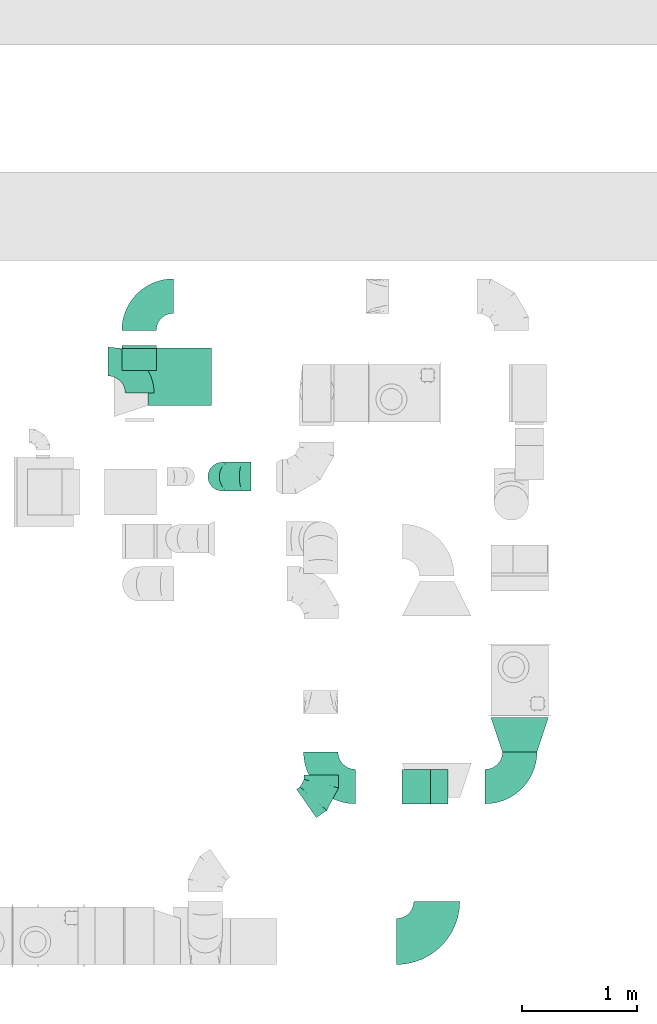
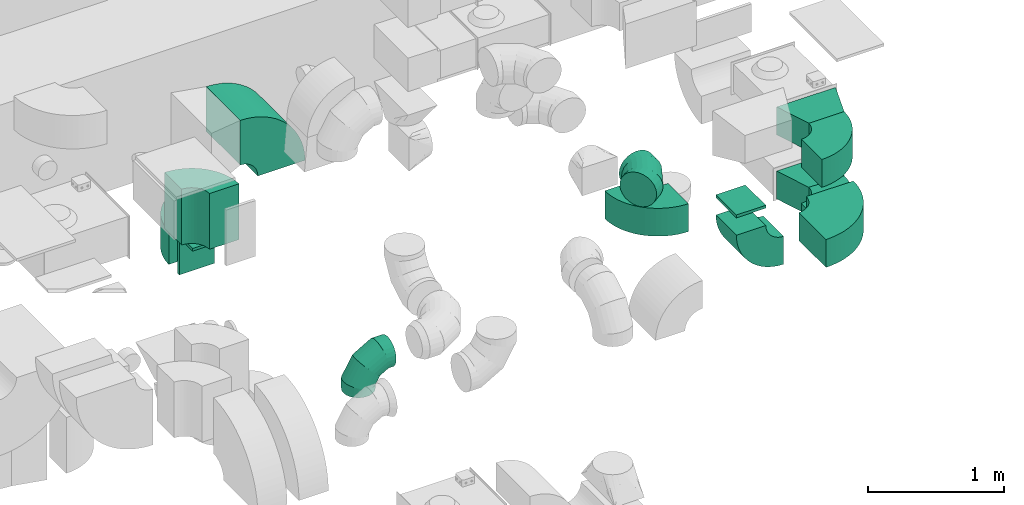
# One storey, part 11 of 59: 15 flow fittings.
"""IFC2X3 building model written with IfcOpenShell, lengths in millimetres."""

import ifcopenshell
import ifcopenshell.guid

model = None  # the IFC model being written
_history = None  # IfcOwnerHistory: only IFC2X3 demands one
_inside = {}  # id of a spatial element -> (the spatial element, [elements in it])
_under = {}  # id of a project, library or spatial element -> (it, [spatial elements below it])
_declared = {}  # id of a project -> (the project, [libraries it declares])
_typed = {}  # id of a type object -> (the type object, [elements of that type])
_made_of = {}  # id of a material, layer set ... -> (it, [elements and type objects made of it])


def new_model(schema):
    """Start an empty IFC model of exactly this schema.

    Asked for "IFC4X3", IfcOpenShell would pick the latest addendum, in which some entities
    have other attributes; the version numbers below select the first issue.
    IFC2X3 requires an IfcOwnerHistory on every rooted entity: one is made here for all.
    """
    global model, _history
    if schema == "IFC4X3":
        model = ifcopenshell.file(schema_version=(4, 3, 0, 0))
    else:
        model = ifcopenshell.file(schema=schema)
    _inside.clear()
    _under.clear()
    _declared.clear()
    _typed.clear()
    _made_of.clear()
    _history = None
    if model.schema == "IFC2X3":
        org = make("IfcOrganization", Name="unknown")
        user = make(
            "IfcPersonAndOrganization",
            ThePerson=make("IfcPerson", FamilyName="unknown"),
            TheOrganization=org,
        )
        app = make(
            "IfcApplication",
            ApplicationDeveloper=org,
            Version="unknown",
            ApplicationFullName="unknown",
            ApplicationIdentifier="unknown",
        )
        _history = make(
            "IfcOwnerHistory",
            OwningUser=user,
            OwningApplication=app,
            ChangeAction="ADDED",
            CreationDate=0,
        )
    return model


def make(cls, **values):
    """One entity of the class cls with the attributes given. An attribute that is None is left unset."""
    return model.create_entity(
        cls, **{name: value for name, value in values.items() if value is not None}
    )


def entity(cls, *values):
    """Any entity or typed value of the class cls, its attributes in the order of the schema. None: left unset."""
    e = model.create_entity(cls)
    for i, value in enumerate(values):
        if value is not None:
            e[i] = value
    return e


def rooted(cls, **values):
    """An entity with a GlobalId (a new one), such as an element, a storey or a relation."""
    return make(cls, GlobalId=ifcopenshell.guid.new(), OwnerHistory=_history, **values)


def si_unit(unit_type, name, prefix=None):
    """IfcSIUnit, for example si_unit("LENGTHUNIT", "METRE", prefix="MILLI")."""
    return make("IfcSIUnit", UnitType=unit_type, Prefix=prefix, Name=name)


def converted_unit(unit_type, name, factor, base, dimensions=None, offset=None):
    """IfcConversionBasedUnit, such as the inch: factor (a typed value) times the base unit."""
    return make(
        "IfcConversionBasedUnit"
        if offset is None
        else "IfcConversionBasedUnitWithOffset",
        ConversionOffset=offset,
        Dimensions=None
        if dimensions is None
        else entity("IfcDimensionalExponents", *dimensions),
        UnitType=unit_type,
        Name=name,
        ConversionFactor=make(
            "IfcMeasureWithUnit", ValueComponent=factor, UnitComponent=base
        ),
    )


def derived_unit(unit_type, elements):
    """IfcDerivedUnit: a product of units, each with its exponent."""
    return make(
        "IfcDerivedUnit",
        Elements=[
            make("IfcDerivedUnitElement", Unit=unit, Exponent=power)
            for unit, power in elements
        ],
        UnitType=unit_type,
    )


def assignment(units):
    """IfcUnitAssignment: the units of a project."""
    return None if units is None else make("IfcUnitAssignment", Units=units)


def point(xyz):
    """IfcCartesianPoint."""
    return None if xyz is None else make("IfcCartesianPoint", Coordinates=xyz)


def direction(xyz):
    """IfcDirection."""
    return None if xyz is None else make("IfcDirection", DirectionRatios=xyz)


def frame(location, z_axis=None, x_axis=None):
    """IfcAxis2Placement3D, a coordinate frame: its origin and axes. An axis left out is left unset."""
    return make(
        "IfcAxis2Placement3D",
        Location=point(location),
        Axis=direction(z_axis),
        RefDirection=direction(x_axis),
    )


def frame_2d(location, x_axis=None):
    """IfcAxis2Placement2D, a coordinate frame in the plane: its origin and x axis."""
    return make(
        "IfcAxis2Placement2D", Location=point(location), RefDirection=direction(x_axis)
    )


def origin():
    """The frame at (0, 0, 0) with its axes left unset."""
    return frame((0.0, 0.0, 0.0))


def origin_2d_with_axis():
    """The frame at (0, 0) in the plane with the x axis (1, 0) written out."""
    return frame_2d((0.0, 0.0), x_axis=(1.0, 0.0))


def place(relative_to, where):
    """IfcLocalPlacement: puts the frame where relative to a parent placement (None: the world)."""
    return make(
        "IfcLocalPlacement", PlacementRelTo=relative_to, RelativePlacement=where
    )


def context(
    kind, dimensions, precision=None, world=None, true_north=None, identifier=None
):
    """IfcGeometricRepresentationContext, for example the 3D "Model" context."""
    return make(
        "IfcGeometricRepresentationContext",
        ContextIdentifier=identifier,
        ContextType=kind,
        CoordinateSpaceDimension=dimensions,
        Precision=precision,
        WorldCoordinateSystem=world,
        TrueNorth=true_north,
    )


def subcontext(parent, identifier, kind, view, scale=None):
    """IfcGeometricRepresentationSubContext, for example "Body" below "Model"."""
    return make(
        "IfcGeometricRepresentationSubContext",
        ContextIdentifier=identifier,
        ContextType=kind,
        ParentContext=parent,
        TargetScale=scale,
        TargetView=view,
    )


def project(units=None, contexts=None):
    """IfcProject with its units and contexts."""
    return rooted(
        "IfcProject",
        Name="project",
        RepresentationContexts=contexts,
        UnitsInContext=assignment(units),
    )


def spatial(cls, under=None, at=None, **own):
    """A site, building, storey or space (cls), placed at a placement, below another one or the project."""
    s = rooted(cls, ObjectPlacement=at, **own)
    if under is not None:
        _under.setdefault(under.id(), (under, []))[1].append(s)
    return s


def polyline(points):
    """IfcPolyline through the points."""
    return make("IfcPolyline", Points=[point(p) for p in points])


def circle_curve(where, radius):
    """IfcCircle in the frame where."""
    return make("IfcCircle", Position=where, Radius=radius)


def parameter(value):
    """IfcParameterValue: where a trimmed curve begins or ends, as a parameter of its basis curve."""
    return model.create_entity("IfcParameterValue", value)


def trimmed(basis, trim1, trim2, sense, master):
    """IfcTrimmedCurve: the piece of a basis curve between two trims."""
    return make(
        "IfcTrimmedCurve",
        BasisCurve=basis,
        Trim1=trim1,
        Trim2=trim2,
        SenseAgreement=sense,
        MasterRepresentation=master,
    )


def segment(curve, same_sense, transition):
    """IfcCompositeCurveSegment."""
    return make(
        "IfcCompositeCurveSegment",
        Transition=transition,
        SameSense=same_sense,
        ParentCurve=curve,
    )


def composite_curve(segments, self_intersect=None):
    """IfcCompositeCurve: segments joined end to end."""
    return make("IfcCompositeCurve", Segments=segments, SelfIntersect=self_intersect)


def profile(cls, at=None, kind="AREA", **sizes):
    """A parametric profile (cls). Its sizes go by their IFC names, for example OverallWidth=200.0."""
    return make(cls, ProfileType=kind, Position=at, **sizes)


def rectangle(**sizes):
    """IfcRectangleProfileDef."""
    return profile("IfcRectangleProfileDef", **sizes)


def outline(outer, holes=None, kind="AREA"):
    """IfcArbitraryClosedProfileDef: a profile drawn as a closed curve; with holes, ...WithVoids."""
    if holes is None:
        return make("IfcArbitraryClosedProfileDef", ProfileType=kind, OuterCurve=outer)
    return make(
        "IfcArbitraryProfileDefWithVoids",
        ProfileType=kind,
        OuterCurve=outer,
        InnerCurves=holes,
    )


def extrude(swept, where, along, depth):
    """IfcExtrudedAreaSolid: the profile swept, set in the frame where, extruded along a direction by depth."""
    return make(
        "IfcExtrudedAreaSolid",
        SweptArea=swept,
        Position=where,
        ExtrudedDirection=direction(along),
        Depth=depth,
    )


def faces_of(points, faces, orient=None, outer=None):
    """IfcFace entities. A face is a list of loops; a loop is a list of indices into points, from 0.

    orient and outer hold one flag for each loop. By default every Orientation is true, the
    first loop of a face is its IfcFaceOuterBound and the others are IfcFaceBound.
    """
    made = []
    for i, loops in enumerate(faces):
        bounds = []
        for j, loop in enumerate(loops):
            is_outer = j == 0 if outer is None else outer[i][j]
            bounds.append(
                make(
                    "IfcFaceOuterBound" if is_outer else "IfcFaceBound",
                    Bound=make("IfcPolyLoop", Polygon=[points[k] for k in loop]),
                    Orientation=True if orient is None else orient[i][j],
                )
            )
        made.append(make("IfcFace", Bounds=bounds))
    return made


def faceted_brep(points, faces, orient=None, outer=None, voids=None):
    """IfcFacetedBrep: a solid bounded by flat faces; with voids (closed shells), ...WithVoids."""
    shared = [point(p) for p in points]
    hull = make("IfcClosedShell", CfsFaces=faces_of(shared, faces, orient, outer))
    if voids is None:
        return make("IfcFacetedBrep", Outer=hull)
    return make(
        "IfcFacetedBrepWithVoids",
        Outer=hull,
        Voids=[
            make(cls, CfsFaces=faces_of(shared, fs, o, b)) for cls, fs, o, b in voids
        ],
    )


def shape(context_of_items, identifier, shape_type, items):
    """IfcShapeRepresentation: the items that make up one representation, for example the "Body"."""
    return make(
        "IfcShapeRepresentation",
        ContextOfItems=context_of_items,
        RepresentationIdentifier=identifier,
        RepresentationType=shape_type,
        Items=items,
    )


def source(mapping_origin, context_of_items, identifier, shape_type, items):
    """IfcRepresentationMap: a shape defined once, which mapped items show again and again."""
    return make(
        "IfcRepresentationMap",
        MappingOrigin=mapping_origin,
        MappedRepresentation=shape(context_of_items, identifier, shape_type, items),
    )


def transform(
    local_origin,
    x_axis=None,
    y_axis=None,
    z_axis=None,
    scale=None,
    scale2=None,
    scale3=None,
    uniform=True,
):
    """IfcCartesianTransformationOperator3D, or its non-uniform kind. x_axis, y_axis, z_axis: its Axis1, 2, 3."""
    if uniform:
        return make(
            "IfcCartesianTransformationOperator3D",
            Axis1=direction(x_axis),
            Axis2=direction(y_axis),
            LocalOrigin=point(local_origin),
            Scale=scale,
            Axis3=direction(z_axis),
        )
    return make(
        "IfcCartesianTransformationOperator3DnonUniform",
        Axis1=direction(x_axis),
        Axis2=direction(y_axis),
        LocalOrigin=point(local_origin),
        Scale=scale,
        Axis3=direction(z_axis),
        Scale2=scale2,
        Scale3=scale3,
    )


def mapped(mapping_source, mapping_target):
    """IfcMappedItem: shows the shape of a source again, moved by a transform."""
    return make(
        "IfcMappedItem", MappingSource=mapping_source, MappingTarget=mapping_target
    )


def material(Name=None, Category=None):
    """IfcMaterial."""
    return make("IfcMaterial", Name=Name, Category=Category)


def made_of(thing, what):
    """Note that an element or type object is made of a material, layer set ...; save() writes the relation."""
    if what is not None:
        _made_of.setdefault(what.id(), (what, []))[1].append(thing)
    return thing


def type_object(cls, material=None, **own):
    """A type object (cls), such as IfcWallType, which elements share."""
    return made_of(rooted(cls, **own), material)


def type_shapes(of_type, sources):
    """Give a type object the sources (RepresentationMaps) that its elements show as mapped items."""
    of_type.RepresentationMaps = sources


def element(
    cls,
    number,
    at=None,
    inside=None,
    cuts=None,
    type_object=None,
    material=None,
    context=None,
    identifier="Body",
    shape_type=None,
    held_by="IfcProductDefinitionShape",
    body=None,
    shapes=None,
    **own,
):
    """One element of the class cls, such as IfcWall. Its Tag is "e" and its number.

    at: its placement. inside: the storey or other place that contains it. cuts: it is an
    opening in that element (IfcRelVoidsElement). A single representation is given by context,
    identifier, shape_type and body (its items); several are given by shapes. held_by: the class
    of the entity that holds the representations. save() writes the other relations.
    """
    e = rooted(cls, Tag="e%d" % number, ObjectPlacement=at, **own)
    if body is not None:
        shapes = [shape(context, identifier, shape_type, body)]
    if shapes is not None:
        e.Representation = make(held_by, Representations=shapes)
    if inside is not None:
        _inside.setdefault(inside.id(), (inside, []))[1].append(e)
    if cuts is not None:
        rooted(
            "IfcRelVoidsElement", RelatingBuildingElement=cuts, RelatedOpeningElement=e
        )
    if type_object is not None:
        _typed.setdefault(type_object.id(), (type_object, []))[1].append(e)
    return made_of(e, material)


def aggregate(whole, parts):
    """IfcRelAggregates: a whole, such as a stair, and the parts it consists of."""
    return rooted("IfcRelAggregates", RelatingObject=whole, RelatedObjects=parts)


def save(model, path):
    """Write the relations noted so far, then the file.

    IfcRelAggregates (storeys below a building ...), IfcRelContainedInSpatialStructure (elements
    in a storey), IfcRelDefinesByType, IfcRelAssociatesMaterial and IfcRelDeclares: one each for
    every whole, place, type object, material and project.
    """
    for whole, parts in _under.values():
        aggregate(whole, parts)
    for where, things in _inside.values():
        rooted(
            "IfcRelContainedInSpatialStructure",
            RelatedElements=things,
            RelatingStructure=where,
        )
    for kind, things in _typed.values():
        rooted("IfcRelDefinesByType", RelatedObjects=things, RelatingType=kind)
    for what, things in _made_of.values():
        rooted("IfcRelAssociatesMaterial", RelatedObjects=things, RelatingMaterial=what)
    for by, libraries in _declared.values():
        rooted("IfcRelDeclares", RelatingContext=by, RelatedDefinitions=libraries)
    model.write(path)


model = new_model("IFC2X3")

# Units and contexts
model_context = context("Model", 3, precision=0.01, world=origin(), true_north=direction((6.12303176911189e-17, 1.0)))
body_context = subcontext(model_context, "Body", "Model", "MODEL_VIEW")
ifc_project = project(units=[si_unit("LENGTHUNIT", "METRE", prefix="MILLI"), si_unit("AREAUNIT", "SQUARE_METRE"), si_unit("VOLUMEUNIT", "CUBIC_METRE"), converted_unit("PLANEANGLEUNIT", "DEGREE", entity("IfcRatioMeasure", 0.0174532925199433), si_unit("PLANEANGLEUNIT", "RADIAN"), dimensions=[0, 0, 0, 0, 0, 0, 0]), si_unit("MASSUNIT", "GRAM", prefix="KILO"), derived_unit("MASSDENSITYUNIT", [(si_unit("MASSUNIT", "GRAM", prefix="KILO"), 1), (si_unit("LENGTHUNIT", "METRE"), -3)]), derived_unit("MOMENTOFINERTIAUNIT", [(si_unit("LENGTHUNIT", "METRE"), 4)]), si_unit("TIMEUNIT", "SECOND"), si_unit("FREQUENCYUNIT", "HERTZ"), si_unit("THERMODYNAMICTEMPERATUREUNIT", "DEGREE_CELSIUS"), derived_unit("THERMALTRANSMITTANCEUNIT", [(si_unit("MASSUNIT", "GRAM", prefix="KILO"), 1), (si_unit("THERMODYNAMICTEMPERATUREUNIT", "KELVIN"), -1), (si_unit("TIMEUNIT", "SECOND"), -3)]), derived_unit("VOLUMETRICFLOWRATEUNIT", [(si_unit("LENGTHUNIT", "METRE"), 3), (si_unit("TIMEUNIT", "SECOND"), -1)]), derived_unit("MASSFLOWRATEUNIT", [(si_unit("MASSUNIT", "GRAM", prefix="KILO"), 1), (si_unit("TIMEUNIT", "SECOND"), -1)]), derived_unit("ROTATIONALFREQUENCYUNIT", [(si_unit("TIMEUNIT", "SECOND"), -1)]), si_unit("ELECTRICCURRENTUNIT", "AMPERE"), si_unit("ELECTRICVOLTAGEUNIT", "VOLT"), si_unit("POWERUNIT", "WATT"), si_unit("FORCEUNIT", "NEWTON", prefix="KILO"), si_unit("ILLUMINANCEUNIT", "LUX"), si_unit("LUMINOUSFLUXUNIT", "LUMEN"), si_unit("LUMINOUSINTENSITYUNIT", "CANDELA"), derived_unit("USERDEFINED", [(si_unit("MASSUNIT", "GRAM", prefix="KILO"), -1), (si_unit("LENGTHUNIT", "METRE"), -2), (si_unit("TIMEUNIT", "SECOND"), 3), (si_unit("LUMINOUSFLUXUNIT", "LUMEN"), 1)]), derived_unit("LINEARVELOCITYUNIT", [(si_unit("LENGTHUNIT", "METRE"), 1), (si_unit("TIMEUNIT", "SECOND"), -1)]), si_unit("PRESSUREUNIT", "PASCAL"), derived_unit("USERDEFINED", [(si_unit("LENGTHUNIT", "METRE"), -2), (si_unit("MASSUNIT", "GRAM", prefix="KILO"), 1), (si_unit("TIMEUNIT", "SECOND"), -2)]), derived_unit("LINEARFORCEUNIT", [(si_unit("MASSUNIT", "GRAM", prefix="KILO"), 1), (si_unit("LENGTHUNIT", "METRE"), 1), (si_unit("TIMEUNIT", "SECOND"), -2), (si_unit("LENGTHUNIT", "METRE"), -1)]), derived_unit("PLANARFORCEUNIT", [(si_unit("MASSUNIT", "GRAM", prefix="KILO"), 1), (si_unit("LENGTHUNIT", "METRE"), 1), (si_unit("TIMEUNIT", "SECOND"), -2), (si_unit("LENGTHUNIT", "METRE"), -2)])], contexts=[model_context])

# Site, building, storey
site_placement = place(None, origin())
site = spatial("IfcSite", under=ifc_project, at=site_placement, CompositionType="ELEMENT")
building_placement = place(site_placement, origin())
building = spatial("IfcBuilding", under=site, at=building_placement, CompositionType="ELEMENT")
storey_placement = place(building_placement, frame((0.0, 0.0, 28200.0)))
storey = spatial("IfcBuildingStorey", under=building, at=storey_placement, CompositionType="ELEMENT", Elevation=28200.0)

# Flow fittings
ifc_material = material()
duct_fitting_type_1 = type_object("IfcDuctFittingType", PredefinedType="NOTDEFINED", material=ifc_material)
shared_shape_1 = source(origin(), body_context, "Body", "SweptSolid", [
    extrude(rectangle(XDim=26.0960000000005, YDim=300.0, at=origin_2d_with_axis()), frame((6.95, 0.0, -150.0)), (0.0, 0.0, 1.0), 300.0),
])
type_shapes(duct_fitting_type_1, [shared_shape_1])
flow_fitting_1_placement = place(storey_placement, frame((31134.49, 13299.88, 1044.78), z_axis=(1.0, 0.0, 0.0), x_axis=(0.0, 1.0, 0.0)))
element("IfcFlowFitting", 1, at=flow_fitting_1_placement, inside=storey, type_object=duct_fitting_type_1, material=ifc_material, context=body_context, shape_type="MappedRepresentation", body=[
    mapped(shared_shape_1, transform((0.0, 0.0, 0.0), scale=1.0)),
])
duct_fitting_type_2 = type_object("IfcDuctFittingType", PredefinedType="NOTDEFINED", material=ifc_material)
shared_shape_2 = source(origin(), body_context, "Body", "SweptSolid", [
    extrude(rectangle(XDim=300.0, YDim=26.0960000000087, at=origin_2d_with_axis()), frame((6.95, 0.0, -125.0), z_axis=(0.0, 0.0, 1.0), x_axis=(0.0, -1.0, 0.0)), (0.0, 0.0, 1.0), 250.0),
])
type_shapes(duct_fitting_type_2, [shared_shape_2])
flow_fitting_2_placement = place(storey_placement, frame((33546.59, 9482.41, 2975.0), z_axis=(1.0, 0.0, 0.0), x_axis=(0.0, 0.0, -1.0)))
element("IfcFlowFitting", 2, at=flow_fitting_2_placement, inside=storey, type_object=duct_fitting_type_2, material=ifc_material, context=body_context, shape_type="MappedRepresentation", body=[
    mapped(shared_shape_2, transform((0.0, 0.0, 0.0), scale=1.0)),
])
duct_fitting_type_3 = type_object("IfcDuctFittingType", PredefinedType="NOTDEFINED", material=ifc_material)
shared_shape_3 = source(origin(), body_context, "Body", "SweptSolid", [
    extrude(rectangle(XDim=24.9999999999999, YDim=300.0, at=origin_2d_with_axis()), frame((12.5, 0.0, -100.0)), (0.0, 0.0, 1.0), 200.0),
])
type_shapes(duct_fitting_type_3, [shared_shape_3])
flow_fitting_3_placement = place(storey_placement, frame((31134.33, 13199.88, 1224.78), z_axis=(0.0, 1.0, 0.0), x_axis=(0.0, 0.0, 1.0)))
element("IfcFlowFitting", 3, at=flow_fitting_3_placement, inside=storey, type_object=duct_fitting_type_3, material=ifc_material, context=body_context, shape_type="MappedRepresentation", body=[
    mapped(shared_shape_3, transform((0.0, 0.0, 0.0), scale=1.0)),
])
duct_fitting_type_4 = type_object("IfcDuctFittingType", PredefinedType="NOTDEFINED", material=ifc_material)
shared_shape_4 = source(origin(), body_context, "Body", "SweptSolid", [
    extrude(outline(polyline([(-221.36, -189.74), (94.87, -189.74), (189.74, 94.87), (-63.25, 284.6), (-221.36, -189.74)])), frame((150.0, 0.0, -125.0), z_axis=(0.0, 0.0, 1.0), x_axis=(0.948683298050514, 0.316227766016836, 0.0)), (0.0, 0.0, 1.0), 250.0),
])
type_shapes(duct_fitting_type_4, [shared_shape_4])
for number, where, z_axis, x_axis in (
    (4, (34445.98, 10082.41, 3100.0), (0.0, 0.0, 1.0), (0.0, -1.0, 0.0)),
    (5, (34445.98, 10082.41, 2525.0), (0.0, 0.0, 1.0), (0.0, -1.0, 0.0)),
):
    element("IfcFlowFitting", number, at=place(storey_placement, frame(where, z_axis=z_axis, x_axis=x_axis)), inside=storey, type_object=duct_fitting_type_4, material=ifc_material, context=body_context, shape_type="MappedRepresentation", body=[
        mapped(shared_shape_4, transform((0.0, 0.0, 0.0), scale=1.0)),
    ])
duct_fitting_type_5 = type_object("IfcDuctFittingType", PredefinedType="NOTDEFINED", material=ifc_material)
shared_shape_5 = source(origin(), body_context, "Body", "Brep", [
    faceted_brep([(-250.0, 0.0, -125.0), (-250.0, -32.35, -120.74), (-250.0, -62.5, -108.25), (-250.0, -88.39, -88.39), (-250.0, -108.25, -62.5), (-250.0, -120.74, -32.35), (-250.0, -125.0, 0.0), (-250.0, -120.74, 32.35), (-250.0, -108.25, 62.5), (-250.0, -88.39, 88.39), (-250.0, -62.5, 108.25), (-250.0, -32.35, 120.74), (-250.0, 0.0, 125.0), (-250.0, 32.35, 120.74), (-250.0, 62.5, 108.25), (-250.0, 88.39, 88.39), (-250.0, 108.25, 62.5), (-250.0, 120.74, 32.35), (-250.0, 125.0, 0.0), (-250.0, 120.74, -32.35), (-250.0, 108.25, -62.5), (-250.0, 88.39, -88.39), (-250.0, 62.5, -108.25), (-250.0, 32.35, -120.74), (-191.68, 32.35, 120.74), (-199.76, 62.5, 108.25), (-183.01, 0.0, 125.0), (-206.7, 88.39, 88.39), (-215.37, 120.74, 32.35), (-216.51, 125.0, 0.0), (-212.02, 108.25, 62.5), (-212.02, 108.25, -62.5), (-206.7, 88.39, -88.39), (-215.37, 120.74, -32.35), (-191.68, 32.35, -120.74), (-183.01, 0.0, -125.0), (-199.76, 62.5, -108.25), (-174.34, -32.35, -120.74), (-166.27, -62.5, -108.25), (-159.33, -88.39, -88.39), (-154.01, -108.25, -62.5), (-150.66, -120.74, -32.35), (-149.52, -125.0, 0.0), (-150.66, -120.74, 32.35), (-154.01, -108.25, 62.5), (-159.33, -88.39, 88.39), (-166.27, -62.5, 108.25), (-174.34, -32.35, 120.74), (-90.67, 90.67, 120.74), (-112.74, 112.74, 108.25), (-66.99, 66.99, 125.0), (-131.69, 131.69, 88.39), (-146.23, 146.23, 62.5), (-155.38, 155.38, 32.35), (-158.49, 158.49, 0.0), (-155.38, 155.38, -32.35), (-146.23, 146.23, -62.5), (-131.69, 131.69, -88.39), (-90.67, 90.67, -120.74), (-66.99, 66.99, -125.0), (-112.74, 112.74, -108.25), (-43.3, 43.3, -120.74), (-21.23, 21.23, -108.25), (-2.28, 2.28, -88.39), (12.26, -12.26, -62.5), (21.4, -21.4, -32.35), (24.52, -24.52, 0.0), (21.4, -21.4, 32.35), (12.26, -12.26, 62.5), (-2.28, 2.28, 88.39), (-21.23, 21.23, 108.25), (-43.3, 43.3, 120.74), (-32.35, 191.68, 120.74), (-62.5, 199.76, 108.25), (0.0, 183.01, 125.0), (-88.39, 206.7, 88.39), (-108.25, 212.02, 62.5), (-120.74, 215.37, 32.35), (-125.0, 216.51, 0.0), (-120.74, 215.37, -32.35), (-108.25, 212.02, -62.5), (-88.39, 206.7, -88.39), (-32.35, 191.68, -120.74), (0.0, 183.01, -125.0), (-62.5, 199.76, -108.25), (32.35, 174.34, -120.74), (62.5, 166.27, -108.25), (88.39, 159.33, -88.39), (108.25, 154.01, -62.5), (120.74, 150.66, -32.35), (125.0, 149.52, 0.0), (120.74, 150.66, 32.35), (108.25, 154.01, 62.5), (88.39, 159.33, 88.39), (62.5, 166.27, 108.25), (32.35, 174.34, 120.74), (-32.35, 250.0, -120.74), (-62.5, 250.0, -108.25), (-88.39, 250.0, -88.39), (-108.25, 250.0, -62.5), (-120.74, 250.0, -32.35), (-125.0, 250.0, 0.0), (-120.74, 250.0, 32.35), (-108.25, 250.0, 62.5), (-88.39, 250.0, 88.39), (-62.5, 250.0, 108.25), (-32.35, 250.0, 120.74), (0.0, 250.0, 125.0), (32.35, 250.0, 120.74), (62.5, 250.0, 108.25), (88.39, 250.0, 88.39), (108.25, 250.0, 62.5), (120.74, 250.0, 32.35), (125.0, 250.0, 0.0), (120.74, 250.0, -32.35), (108.25, 250.0, -62.5), (88.39, 250.0, -88.39), (62.5, 250.0, -108.25), (32.35, 250.0, -120.74), (0.0, 250.0, -125.0)], [[[0, 1, 2, 3, 4, 5, 6, 7, 8, 9, 10, 11, 12, 13, 14, 15, 16, 17, 18, 19, 20, 21, 22, 23]], [[24, 25, 14, 13]], [[26, 24, 13, 12]], [[14, 25, 27, 15]], [[28, 29, 18, 17]], [[30, 28, 17, 16]], [[15, 27, 30, 16]], [[20, 31, 32, 21]], [[33, 31, 20, 19]], [[18, 29, 33, 19]], [[34, 35, 0, 23]], [[36, 34, 23, 22]], [[21, 32, 36, 22]], [[1, 0, 35, 37]], [[2, 1, 37, 38]], [[38, 39, 3, 2]], [[5, 4, 40, 41]], [[6, 5, 41, 42]], [[39, 40, 4, 3]], [[6, 42, 43, 7]], [[7, 43, 44, 8]], [[8, 44, 45, 9]], [[9, 45, 46, 10]], [[10, 46, 47, 11]], [[26, 12, 11, 47]], [[48, 49, 25, 24]], [[50, 48, 24, 26]], [[27, 25, 49, 51]], [[52, 53, 28, 30]], [[51, 52, 30, 27]], [[29, 28, 53, 54]], [[55, 56, 31, 33]], [[54, 55, 33, 29]], [[32, 31, 56, 57]], [[58, 59, 35, 34]], [[60, 58, 34, 36]], [[57, 60, 36, 32]], [[37, 35, 59, 61]], [[38, 37, 61, 62]], [[39, 38, 62, 63]], [[41, 40, 64, 65]], [[42, 41, 65, 66]], [[63, 64, 40, 39]], [[43, 42, 66, 67]], [[44, 43, 67, 68]], [[68, 69, 45, 44]], [[46, 45, 69, 70]], [[47, 46, 70, 71]], [[26, 47, 71, 50]], [[72, 73, 49, 48]], [[74, 72, 48, 50]], [[51, 49, 73, 75]], [[76, 77, 53, 52]], [[75, 76, 52, 51]], [[54, 53, 77, 78]], [[79, 80, 56, 55]], [[78, 79, 55, 54]], [[57, 56, 80, 81]], [[82, 83, 59, 58]], [[84, 82, 58, 60]], [[81, 84, 60, 57]], [[61, 59, 83, 85]], [[62, 61, 85, 86]], [[63, 62, 86, 87]], [[65, 64, 88, 89]], [[66, 65, 89, 90]], [[87, 88, 64, 63]], [[67, 66, 90, 91]], [[68, 67, 91, 92]], [[92, 93, 69, 68]], [[70, 69, 93, 94]], [[71, 70, 94, 95]], [[50, 71, 95, 74]], [[96, 97, 98, 99, 100, 101, 102, 103, 104, 105, 106, 107, 108, 109, 110, 111, 112, 113, 114, 115, 116, 117, 118, 119]], [[72, 74, 107, 106]], [[73, 72, 106, 105]], [[75, 73, 105, 104]], [[77, 76, 103, 102]], [[78, 77, 102, 101]], [[75, 104, 103, 76]], [[78, 101, 100, 79]], [[79, 100, 99, 80]], [[80, 99, 98, 81]], [[84, 97, 96, 82]], [[82, 96, 119, 83]], [[84, 81, 98, 97]], [[83, 119, 118, 85]], [[85, 118, 117, 86]], [[116, 87, 86, 117]], [[88, 115, 114, 89]], [[89, 114, 113, 90]], [[115, 88, 87, 116]], [[91, 90, 113, 112]], [[92, 91, 112, 111]], [[111, 110, 93, 92]], [[95, 94, 109, 108]], [[74, 95, 108, 107]], [[110, 109, 94, 93]]]),
])
type_shapes(duct_fitting_type_5, [shared_shape_5])
flow_fitting_4_placement = place(storey_placement, frame((31857.99, 12178.65, 500.0), z_axis=(0.0, -1.0, 0.0), x_axis=(-1.0, 0.0, 0.0)))
element("IfcFlowFitting", 6, at=flow_fitting_4_placement, inside=storey, type_object=duct_fitting_type_5, material=ifc_material, context=body_context, shape_type="MappedRepresentation", body=[
    mapped(shared_shape_5, transform((0.0, 0.0, 0.0), scale=1.0)),
])
duct_fitting_type_6 = type_object("IfcDuctFittingType", PredefinedType="NOTDEFINED", material=ifc_material)
shared_shape_6 = source(origin(), body_context, "Body", "Brep", [
    faceted_brep([(-157.09, 0.0, -150.0), (-157.09, -38.82, -144.89), (-157.09, -75.0, -129.9), (-157.09, -106.07, -106.07), (-157.09, -129.9, -75.0), (-157.09, -144.89, -38.82), (-157.09, -150.0, 0.0), (-157.09, -144.89, 38.82), (-157.09, -129.9, 75.0), (-157.09, -106.07, 106.07), (-157.09, -75.0, 129.9), (-157.09, -38.82, 144.89), (-157.09, 0.0, 150.0), (-157.09, 38.82, 144.89), (-157.09, 75.0, 129.9), (-157.09, 106.07, 106.07), (-157.09, 129.9, 75.0), (-157.09, 144.89, 38.82), (-157.09, 150.0, 0.0), (-157.09, 144.89, -38.82), (-157.09, 129.9, -75.0), (-157.09, 106.07, -106.07), (-157.09, 75.0, -129.9), (-157.09, 38.82, -144.89), (-92.85, 38.82, 144.89), (-101.74, 75.0, 129.9), (-83.3, 0.0, 150.0), (-109.39, 106.07, 106.07), (-115.25, 129.9, 75.0), (-118.93, 144.89, 38.82), (-120.19, 150.0, 0.0), (-118.93, 144.89, -38.82), (-115.25, 129.9, -75.0), (-109.39, 106.07, -106.07), (-92.85, 38.82, -144.89), (-83.3, 0.0, -150.0), (-101.74, 75.0, -129.9), (-73.75, -38.82, -144.89), (-64.85, -75.0, -129.9), (-57.21, -106.07, -106.07), (-51.34, -129.9, -75.0), (-47.66, -144.89, -38.82), (-46.4, -150.0, 0.0), (-47.66, -144.89, 38.82), (-51.34, -129.9, 75.0), (-57.21, -106.07, 106.07), (-64.85, -75.0, 129.9), (-73.75, -38.82, 144.89), (20.98, 98.42, 144.89), (-3.69, 126.35, 129.9), (47.45, 68.46, 150.0), (-24.87, 150.32, 106.07), (-41.12, 168.72, 75.0), (-51.34, 180.29, 38.82), (-54.82, 184.23, 0.0), (-51.34, 180.29, -38.82), (-41.12, 168.72, -75.0), (-24.87, 150.32, -106.07), (20.98, 98.42, -144.89), (47.45, 68.46, -150.0), (-3.69, 126.35, -129.9), (73.92, 38.5, -144.89), (98.58, 10.58, -129.9), (119.76, -13.4, -106.07), (136.01, -31.8, -75.0), (146.23, -43.36, -38.82), (149.72, -47.31, 0.0), (146.23, -43.36, 38.82), (136.01, -31.8, 75.0), (119.76, -13.4, 106.07), (98.58, 10.58, 129.9), (73.92, 38.5, 144.89), (89.48, 129.11, 150.0), (57.57, 151.22, 144.89), (27.84, 171.83, 129.9), (2.31, 189.53, 106.07), (-17.29, 203.11, 75.0), (-29.6, 211.64, 38.82), (-33.8, 214.56, 0.0), (-29.6, 211.64, -38.82), (-17.29, 203.11, -75.0), (2.31, 189.53, -106.07), (27.84, 171.83, -129.9), (57.57, 151.22, -144.89), (89.48, 129.11, -150.0), (121.39, 107.0, -144.89), (151.12, 86.39, -129.9), (176.66, 68.69, -106.07), (196.25, 55.11, -75.0), (208.57, 46.58, -38.82), (212.77, 43.67, 0.0), (208.57, 46.58, 38.82), (196.25, 55.11, 75.0), (176.66, 68.69, 106.07), (151.12, 86.39, 129.9), (121.39, 107.0, 144.89)], [[[0, 1, 2, 3, 4, 5, 6, 7, 8, 9, 10, 11, 12, 13, 14, 15, 16, 17, 18, 19, 20, 21, 22, 23]], [[24, 25, 14, 13]], [[26, 24, 13, 12]], [[27, 15, 14, 25]], [[28, 29, 17, 16]], [[28, 16, 15, 27]], [[30, 18, 17, 29]], [[31, 32, 20, 19]], [[30, 31, 19, 18]], [[21, 20, 32, 33]], [[34, 35, 0, 23]], [[36, 34, 23, 22]], [[33, 36, 22, 21]], [[1, 0, 35, 37]], [[2, 1, 37, 38]], [[38, 39, 3, 2]], [[5, 4, 40, 41]], [[6, 5, 41, 42]], [[39, 40, 4, 3]], [[6, 42, 43, 7]], [[7, 43, 44, 8]], [[8, 44, 45, 9]], [[9, 45, 46, 10]], [[10, 46, 47, 11]], [[26, 12, 11, 47]], [[48, 49, 25, 24]], [[50, 48, 24, 26]], [[27, 25, 49, 51]], [[52, 53, 29, 28]], [[51, 52, 28, 27]], [[30, 29, 53, 54]], [[55, 56, 32, 31]], [[54, 55, 31, 30]], [[33, 32, 56, 57]], [[58, 59, 35, 34]], [[60, 58, 34, 36]], [[57, 60, 36, 33]], [[37, 35, 59, 61]], [[38, 37, 61, 62]], [[39, 38, 62, 63]], [[41, 40, 64, 65]], [[42, 41, 65, 66]], [[63, 64, 40, 39]], [[43, 42, 66, 67]], [[44, 43, 67, 68]], [[68, 69, 45, 44]], [[46, 45, 69, 70]], [[47, 46, 70, 71]], [[26, 47, 71, 50]], [[48, 50, 72, 73]], [[49, 48, 73, 74]], [[51, 49, 74, 75]], [[53, 52, 76, 77]], [[54, 53, 77, 78]], [[51, 75, 76, 52]], [[54, 78, 79, 55]], [[55, 79, 80, 56]], [[56, 80, 81, 57]], [[60, 82, 83, 58]], [[58, 83, 84, 59]], [[60, 57, 81, 82]], [[59, 84, 85, 61]], [[61, 85, 86, 62]], [[87, 63, 62, 86]], [[64, 88, 89, 65]], [[65, 89, 90, 66]], [[88, 64, 63, 87]], [[67, 66, 90, 91]], [[68, 67, 91, 92]], [[92, 93, 69, 68]], [[71, 70, 94, 95]], [[50, 71, 95, 72]], [[93, 94, 70, 69]], [[78, 77, 76, 75, 74, 73, 72, 95, 94, 93, 92, 91, 90, 89, 88, 87, 86, 85, 84, 83, 82, 81, 80, 79]]]),
])
type_shapes(duct_fitting_type_6, [shared_shape_6])
flow_fitting_5_placement = place(storey_placement, frame((32720.0, 9424.5, 3500.0), z_axis=(0.0, 0.0, 1.0), x_axis=(0.821899128606517, 0.569633059430233, 0.0)))
element("IfcFlowFitting", 7, at=flow_fitting_5_placement, inside=storey, type_object=duct_fitting_type_6, material=ifc_material, context=body_context, shape_type="MappedRepresentation", body=[
    mapped(shared_shape_6, transform((0.0, 0.0, 0.0), scale=1.0)),
])
duct_fitting_type_7 = type_object("IfcDuctFittingType", PredefinedType="NOTDEFINED", material=ifc_material)
shared_shape_7 = source(origin(), body_context, "Body", "SweptSolid", [
    extrude(outline(composite_curve([segment(polyline([(-300.0, -150.0), (0.0, -150.0)]), True, "CONTINUOUS"), segment(trimmed(circle_curve(frame_2d((150.0, -150.0), x_axis=(0.0, 1.0)), 150.0), [parameter(0.0)], [parameter(90.0)], True, "PARAMETER"), False, "CONTINUOUS"), segment(polyline([(150.0, 0.0), (150.0, 300.0)]), True, "CONTINUOUS"), segment(trimmed(circle_curve(frame_2d((150.0, -150.0), x_axis=(0.0, 1.0)), 450.0), [parameter(0.0)], [parameter(90.0000000000001)], True, "PARAMETER"), True, "CONTINUOUS")], self_intersect=False)), frame((-150.0, 150.0, -125.0), z_axis=(0.0, 0.0, 1.0), x_axis=(-1.0, 0.0, 0.0)), (0.0, 0.0, 1.0), 250.0),
])
type_shapes(duct_fitting_type_7, [shared_shape_7])
for number, where in (
    (8, (34445.98, 9482.41, 3100.0)),
    (9, (34445.98, 9482.41, 2525.0)),
):
    element("IfcFlowFitting", number, at=place(storey_placement, frame(where)), inside=storey, type_object=duct_fitting_type_7, material=ifc_material, context=body_context, shape_type="MappedRepresentation", body=[
        mapped(shared_shape_7, transform((0.0, 0.0, 0.0), scale=1.0)),
    ])
flow_fitting_6_placement = place(storey_placement, frame((32715.69, 9482.41, 3100.0), z_axis=(0.0, 0.0, 1.0), x_axis=(0.0, -1.0, 0.0)))
element("IfcFlowFitting", 10, at=flow_fitting_6_placement, inside=storey, type_object=duct_fitting_type_7, material=ifc_material, context=body_context, shape_type="MappedRepresentation", body=[
    mapped(shared_shape_7, transform((0.0, 0.0, 0.0), scale=1.0)),
])
duct_fitting_type_8 = type_object("IfcDuctFittingType", PredefinedType="NOTDEFINED", material=ifc_material)
shared_shape_8 = source(origin(), body_context, "Body", "SweptSolid", [
    extrude(outline(composite_curve([segment(polyline([(-262.5, -137.5), (-12.5, -137.5)]), True, "CONTINUOUS"), segment(trimmed(circle_curve(frame_2d((137.5, -137.5), x_axis=(0.0, 1.0)), 150.0), [parameter(0.0)], [parameter(90.0000000000001)], True, "PARAMETER"), False, "CONTINUOUS"), segment(polyline([(137.5, 12.5), (137.5, 262.5)]), True, "CONTINUOUS"), segment(trimmed(circle_curve(frame_2d((137.5, -137.5), x_axis=(0.0, 1.0)), 400.0), [parameter(0.0)], [parameter(90.0000000000001)], True, "PARAMETER"), True, "CONTINUOUS")], self_intersect=False)), frame((-137.5, 137.5, -250.0), z_axis=(0.0, 0.0, 1.0), x_axis=(-1.0, 0.0, 0.0)), (0.0, 0.0, 1.0), 500.0),
])
type_shapes(duct_fitting_type_8, [shared_shape_8])
flow_fitting_7_placement = place(storey_placement, frame((31140.11, 13179.49, 1600.01), z_axis=(0.0, 0.0, 1.0), x_axis=(0.0, 1.0, 0.0)))
element("IfcFlowFitting", 11, at=flow_fitting_7_placement, inside=storey, type_object=duct_fitting_type_8, material=ifc_material, context=body_context, shape_type="MappedRepresentation", body=[
    mapped(shared_shape_8, transform((0.0, 0.0, 0.0), scale=1.0)),
])
duct_fitting_type_9 = type_object("IfcDuctFittingType", PredefinedType="NOTDEFINED", material=ifc_material)
shared_shape_9 = source(origin(), body_context, "Body", "SweptSolid", [
    extrude(outline(composite_curve([segment(polyline([(-300.0, -150.0), (0.0, -150.0)]), True, "CONTINUOUS"), segment(trimmed(circle_curve(frame_2d((150.0, -150.0), x_axis=(0.0, 1.0)), 150.0), [parameter(0.0)], [parameter(90.0)], True, "PARAMETER"), False, "CONTINUOUS"), segment(polyline([(150.0, 0.0), (150.0, 300.0)]), True, "CONTINUOUS"), segment(trimmed(circle_curve(frame_2d((150.0, -150.0), x_axis=(0.0, 1.0)), 450.0), [parameter(0.0)], [parameter(90.0000000000001)], True, "PARAMETER"), True, "CONTINUOUS")], self_intersect=False)), frame((-150.0, 150.0, -150.0), z_axis=(0.0, 0.0, 1.0), x_axis=(-1.0, 0.0, 0.0)), (0.0, 0.0, 1.0), 300.0),
])
type_shapes(duct_fitting_type_9, [shared_shape_9])
flow_fitting_8_placement = place(storey_placement, frame((31134.49, 13749.59, 1044.78), z_axis=(0.0, 0.0, 1.0), x_axis=(-1.0, 0.0, 0.0)))
element("IfcFlowFitting", 12, at=flow_fitting_8_placement, inside=storey, type_object=duct_fitting_type_9, material=ifc_material, context=body_context, shape_type="MappedRepresentation", body=[
    mapped(shared_shape_9, transform((0.0, 0.0, 0.0), scale=1.0)),
])
duct_fitting_type_10 = type_object("IfcDuctFittingType", PredefinedType="NOTDEFINED", material=ifc_material)
shared_shape_10 = source(origin(), body_context, "Body", "SweptSolid", [
    extrude(outline(composite_curve([segment(polyline([(-375.0, -175.0), (25.0, -175.0)]), True, "CONTINUOUS"), segment(trimmed(circle_curve(frame_2d((175.0, -175.0), x_axis=(0.0, 1.0)), 150.0), [parameter(0.0)], [parameter(90.0000000000001)], True, "PARAMETER"), False, "CONTINUOUS"), segment(polyline([(175.0, -25.0), (175.0, 375.0)]), True, "CONTINUOUS"), segment(trimmed(circle_curve(frame_2d((175.0, -175.0), x_axis=(0.0, 1.0)), 550.0), [parameter(0.0)], [parameter(90.0)], True, "PARAMETER"), True, "CONTINUOUS")], self_intersect=False)), frame((-175.0, 175.0, -125.0), z_axis=(0.0, 0.0, 1.0), x_axis=(-1.0, 0.0, 0.0)), (0.0, 0.0, 1.0), 250.0),
])
type_shapes(duct_fitting_type_10, [shared_shape_10])
flow_fitting_9_placement = place(storey_placement, frame((33725.03, 8134.51, 3500.0)))
element("IfcFlowFitting", 13, at=flow_fitting_9_placement, inside=storey, type_object=duct_fitting_type_10, material=ifc_material, context=body_context, shape_type="MappedRepresentation", body=[
    mapped(shared_shape_10, transform((0.0, 0.0, 0.0), scale=1.0)),
])
duct_fitting_type_11 = type_object("IfcDuctFittingType", PredefinedType="NOTDEFINED", material=ifc_material)
shared_shape_11 = source(origin(), body_context, "Body", "SweptSolid", [
    extrude(outline(composite_curve([segment(polyline([(-262.5, -137.5), (-12.5, -137.5)]), True, "CONTINUOUS"), segment(trimmed(circle_curve(frame_2d((137.5, -137.5), x_axis=(0.0, 1.0)), 150.0), [parameter(0.0)], [parameter(90.0000000000001)], True, "PARAMETER"), False, "CONTINUOUS"), segment(polyline([(137.5, 12.5), (137.5, 262.5)]), True, "CONTINUOUS"), segment(trimmed(circle_curve(frame_2d((137.5, -137.5), x_axis=(0.0, 1.0)), 400.0), [parameter(0.0)], [parameter(90.0000000000001)], True, "PARAMETER"), True, "CONTINUOUS")], self_intersect=False)), frame((-137.5, 137.5, -150.0), z_axis=(0.0, 0.0, 1.0), x_axis=(-1.0, 0.0, 0.0)), (0.0, 0.0, 1.0), 300.0),
])
type_shapes(duct_fitting_type_11, [shared_shape_11])
flow_fitting_10_placement = place(storey_placement, frame((33546.59, 9482.41, 2525.0), z_axis=(0.0, 1.0, 0.0), x_axis=(-1.0, 0.0, 0.0)))
element("IfcFlowFitting", 14, at=flow_fitting_10_placement, inside=storey, type_object=duct_fitting_type_11, material=ifc_material, context=body_context, shape_type="MappedRepresentation", body=[
    mapped(shared_shape_11, transform((0.0, 0.0, 0.0), scale=1.0)),
])
duct_fitting_type_12 = type_object("IfcDuctFittingType", PredefinedType="NOTDEFINED", material=ifc_material)
shared_shape_12 = source(origin(), body_context, "Body", "SweptSolid", [
    extrude(outline(composite_curve([segment(polyline([(-375.04, -175.0), (24.96, -175.0)]), True, "CONTINUOUS"), segment(trimmed(circle_curve(frame_2d((174.96, -175.0), x_axis=(0.000204721632258043, 0.999999979044503)), 150.0), [parameter(0.0)], [parameter(90.0117296855855)], True, "PARAMETER"), False, "CONTINUOUS"), segment(polyline([(174.99, -25.0), (175.08, 375.0)]), True, "CONTINUOUS"), segment(trimmed(circle_curve(frame_2d((174.96, -175.0), x_axis=(0.000204721632258043, 0.999999979044503)), 550.0), [parameter(0.0)], [parameter(90.0117296855855)], True, "PARAMETER"), True, "CONTINUOUS")], self_intersect=False)), frame((-175.07, 175.04, -250.0), z_axis=(0.0, 0.0, 1.0), x_axis=(-0.999999979044526, -0.000204721632259776, 0.0)), (0.0, 0.0, 1.0), 500.0),
])
type_shapes(duct_fitting_type_12, [shared_shape_12])
flow_fitting_11_placement = place(storey_placement, frame((31564.62, 13048.57, 2300.0), z_axis=(0.0, 1.0, 0.0), x_axis=(1.0, 0.0, 0.0)))
element("IfcFlowFitting", 15, at=flow_fitting_11_placement, inside=storey, type_object=duct_fitting_type_12, material=ifc_material, context=body_context, shape_type="MappedRepresentation", body=[
    mapped(shared_shape_12, transform((0.0, 0.0, 0.0), scale=1.0)),
])

save(model, "model.ifc")
